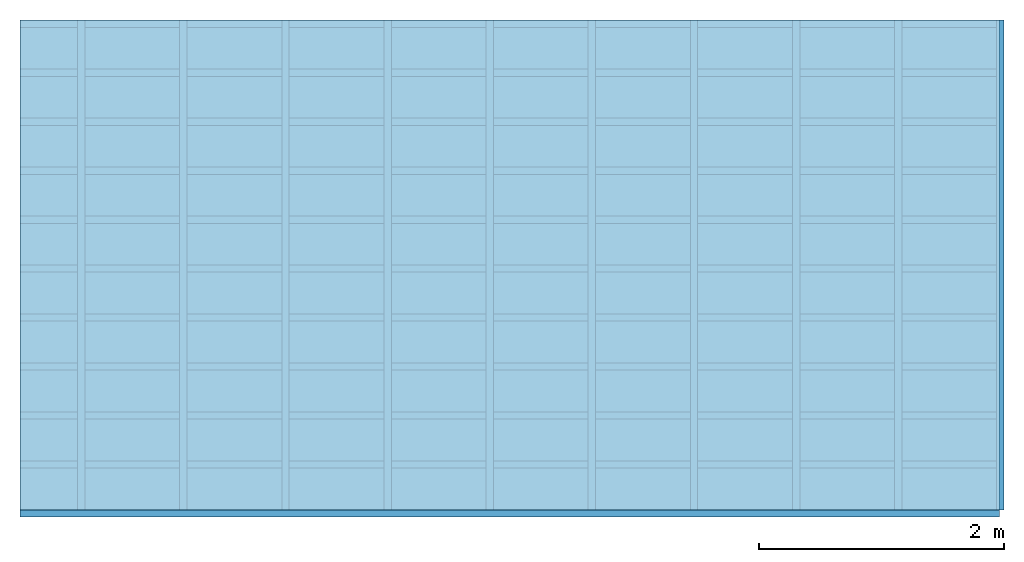
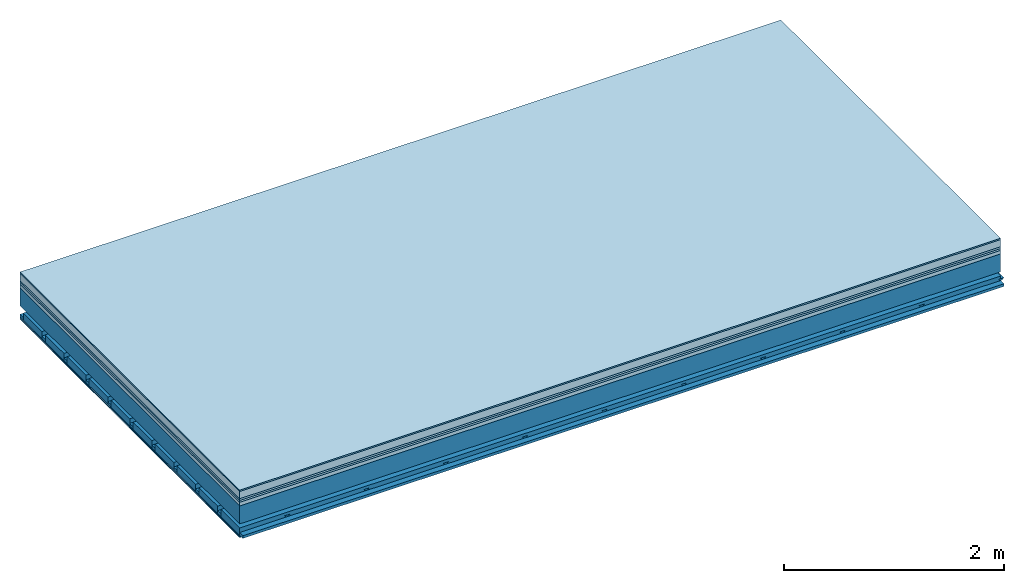
# One storey: 8 plates, 4 members, 1 element without a shape of its own.
"""IFC4 building model written with IfcOpenShell, lengths in metres."""

from ifc_helpers import new_model, si_unit, derived_unit, direction, frame, frame_2d, origin, origin_with_axes, place, context, project, spatial, polyline, rectangle, outline, extrude, material, layer, layer_set, type_object, element, aggregate, save


model = new_model("IFC4")

# Units and contexts
plan_context = context("Plan", 3, precision=1e-05, world=origin(), true_north=direction((0.0, 1.0)))
model_context = context("Model", 3, precision=1e-05, world=origin(), true_north=direction((0.0, 1.0)))
ifc_project = project(units=[si_unit("LENGTHUNIT", "METRE"), derived_unit("SOUNDPRESSUREUNIT", [(si_unit("PRESSUREUNIT", "PASCAL", prefix="MICRO"), 0)]), si_unit("ENERGYUNIT", "JOULE", prefix="MEGA"), si_unit("MASSUNIT", "GRAM", prefix="KILO"), derived_unit("THERMALTRANSMITTANCEUNIT", [(si_unit("POWERUNIT", "WATT"), 1), (si_unit("AREAUNIT", "SQUARE_METRE"), -1), (si_unit("THERMODYNAMICTEMPERATUREUNIT", "KELVIN"), -1)]), derived_unit("AREADENSITYUNIT", [(si_unit("MASSUNIT", "GRAM", prefix="KILO"), 1), (si_unit("AREAUNIT", "SQUARE_METRE"), -1)]), derived_unit("USERDEFINED", [(si_unit("ENERGYUNIT", "JOULE", prefix="MEGA"), 1), (si_unit("AREAUNIT", "SQUARE_METRE"), -1)])], contexts=[plan_context, model_context])

# Site, building, storey
site = spatial("IfcSite", under=ifc_project)
building_placement = place(None, origin())
building = spatial("IfcBuilding", under=site, at=building_placement)
storey_placement = place(building_placement, origin())
storey = spatial("IfcBuildingStorey", under=building, at=storey_placement)

# Slab, members, plates
ifc_material_1 = material(Category="11.013")
ifc_layer_1 = layer(ifc_material_1, 0.015, Name="Flooring")
ifc_material_2 = material(Name="Cement screed", Category="04.006")
ifc_layer_2 = layer(ifc_material_2, 0.08, Name="On-material")
ifc_material_3 = material(Name="Wood fiber generic product", Category="10.009")
ifc_layer_3 = layer(ifc_material_3, 0.02, Name="Impact sound insulation")
ifc_material_4 = material(Category="10.004")
ifc_layer_4 = layer(ifc_material_4, 0.02, Name="Additional insulation")
ifc_material_5 = material(Name="Garden plates", Category="02.007")
ifc_layer_5 = layer(ifc_material_5, 0.04, Name="on Supporting structure")
ifc_material_6 = material(Name="no composite action")
ifc_layer_6 = layer(ifc_material_6, 0.0, Name="Bond")
ifc_layer_7 = layer(None, 0.2, Name="Supporting structure")
ifc_layer_8 = layer(ifc_material_6, 0.0, Name="Bond")
ifc_layer_9 = layer(None, 0.095, Name="Coupling")
ifc_layer_10 = layer(None, 0.03, Name="Battens / profiles")
ifc_material_7 = material(Name="Plasterboard type A", Category="03.008")
ifc_layer_11 = layer(ifc_material_7, 0.0125, Name="Ceiling covering 1st layer")
ifc_layer_12 = layer(ifc_material_7, 0.0125, Name="Ceiling covering layer 2")
ifc_material_8 = material(Category="04.001")
ifc_layer_13 = layer(ifc_material_8, 0.003, Name="Surface / treatment")
ifc_layer_set = layer_set([ifc_layer_1, ifc_layer_2, ifc_layer_3, ifc_layer_4, ifc_layer_5, ifc_layer_6, ifc_layer_7, ifc_layer_8, ifc_layer_9, ifc_layer_10, ifc_layer_11, ifc_layer_12, ifc_layer_13])
slab_type = type_object("IfcSlabType", Name="A2172", PredefinedType="NOTDEFINED", material=ifc_layer_set)
slab_placement = place(None, frame((0.0, 0.0, 0.0), z_axis=(0.0, 0.0, -1.0), x_axis=(1.0, 0.0, 0.0)))
slab = element("IfcSlab", 1, at=slab_placement, inside=storey, type_object=slab_type, material=ifc_layer_set, Name="Slab #1")
ifc_material_9 = material(Name="Solid timber panel")
member_1_placement = place(slab_placement, origin())
member_1 = element("IfcMember", 2, at=member_1_placement, material=ifc_material_9, Name="Supporting structure", context=plan_context, shape_type="SweptSolid", body=[
    extrude(rectangle(XDim=1.0, YDim=0.2, at=frame_2d((0.5, 0.1), x_axis=(1.0, 0.0))), frame((0.0, 4.0, 0.175), z_axis=(0.0, -1.0, 0.0), x_axis=(1.0, 0.0, 0.0)), (0.0, 0.0, 1.0), 4.0),
    extrude(rectangle(XDim=1.0, YDim=0.2, at=frame_2d((0.5, 0.1), x_axis=(1.0, 0.0))), frame((1.0, 4.0, 0.175), z_axis=(0.0, -1.0, 0.0), x_axis=(1.0, 0.0, 0.0)), (0.0, 0.0, 1.0), 4.0),
    extrude(rectangle(XDim=1.0, YDim=0.2, at=frame_2d((0.5, 0.1), x_axis=(1.0, 0.0))), frame((2.0, 4.0, 0.175), z_axis=(0.0, -1.0, 0.0), x_axis=(1.0, 0.0, 0.0)), (0.0, 0.0, 1.0), 4.0),
    extrude(rectangle(XDim=1.0, YDim=0.2, at=frame_2d((0.5, 0.1), x_axis=(1.0, 0.0))), frame((3.0, 4.0, 0.175), z_axis=(0.0, -1.0, 0.0), x_axis=(1.0, 0.0, 0.0)), (0.0, 0.0, 1.0), 4.0),
    extrude(rectangle(XDim=1.0, YDim=0.2, at=frame_2d((0.5, 0.1), x_axis=(1.0, 0.0))), frame((4.0, 4.0, 0.175), z_axis=(0.0, -1.0, 0.0), x_axis=(1.0, 0.0, 0.0)), (0.0, 0.0, 1.0), 4.0),
    extrude(rectangle(XDim=1.0, YDim=0.2, at=frame_2d((0.5, 0.1), x_axis=(1.0, 0.0))), frame((5.0, 4.0, 0.175), z_axis=(0.0, -1.0, 0.0), x_axis=(1.0, 0.0, 0.0)), (0.0, 0.0, 1.0), 4.0),
    extrude(rectangle(XDim=1.0, YDim=0.2, at=frame_2d((0.5, 0.1), x_axis=(1.0, 0.0))), frame((6.0, 4.0, 0.175), z_axis=(0.0, -1.0, 0.0), x_axis=(1.0, 0.0, 0.0)), (0.0, 0.0, 1.0), 4.0),
    extrude(rectangle(XDim=1.0, YDim=0.2, at=frame_2d((0.5, 0.1), x_axis=(1.0, 0.0))), frame((7.0, 4.0, 0.175), z_axis=(0.0, -1.0, 0.0), x_axis=(1.0, 0.0, 0.0)), (0.0, 0.0, 1.0), 4.0),
])
ifc_material_10 = material()
member_2_placement = place(slab_placement, origin())
member_2 = element("IfcMember", 3, at=member_2_placement, material=ifc_material_10, Name="Coupling", context=plan_context, shape_type="SweptSolid", body=[
    extrude(outline(polyline([(0.0, 0.0), (0.06, 0.0), (0.04, 0.02), (0.02, 0.02), (0.0, 0.0)])), frame((0.47, 4.0, 0.45), z_axis=(0.0, -1.0, 0.0), x_axis=(1.0, 0.0, 0.0)), (0.0, 0.0, 1.0), 4.0),
    extrude(outline(polyline([(0.0, 0.0), (0.06, 0.0), (0.04, 0.02), (0.02, 0.02), (0.0, 0.0)])), frame((1.304, 4.0, 0.45), z_axis=(0.0, -1.0, 0.0), x_axis=(1.0, 0.0, 0.0)), (0.0, 0.0, 1.0), 4.0),
    extrude(outline(polyline([(0.0, 0.0), (0.06, 0.0), (0.04, 0.02), (0.02, 0.02), (0.0, 0.0)])), frame((2.138, 4.0, 0.45), z_axis=(0.0, -1.0, 0.0), x_axis=(1.0, 0.0, 0.0)), (0.0, 0.0, 1.0), 4.0),
    extrude(outline(polyline([(0.0, 0.0), (0.06, 0.0), (0.04, 0.02), (0.02, 0.02), (0.0, 0.0)])), frame((2.972, 4.0, 0.45), z_axis=(0.0, -1.0, 0.0), x_axis=(1.0, 0.0, 0.0)), (0.0, 0.0, 1.0), 4.0),
    extrude(outline(polyline([(0.0, 0.0), (0.06, 0.0), (0.04, 0.02), (0.02, 0.02), (0.0, 0.0)])), frame((3.806, 4.0, 0.45), z_axis=(0.0, -1.0, 0.0), x_axis=(1.0, 0.0, 0.0)), (0.0, 0.0, 1.0), 4.0),
    extrude(outline(polyline([(0.0, 0.0), (0.06, 0.0), (0.04, 0.02), (0.02, 0.02), (0.0, 0.0)])), frame((4.64, 4.0, 0.45), z_axis=(0.0, -1.0, 0.0), x_axis=(1.0, 0.0, 0.0)), (0.0, 0.0, 1.0), 4.0),
    extrude(outline(polyline([(0.0, 0.0), (0.06, 0.0), (0.04, 0.02), (0.02, 0.02), (0.0, 0.0)])), frame((5.474, 4.0, 0.45), z_axis=(0.0, -1.0, 0.0), x_axis=(1.0, 0.0, 0.0)), (0.0, 0.0, 1.0), 4.0),
    extrude(outline(polyline([(0.0, 0.0), (0.06, 0.0), (0.04, 0.02), (0.02, 0.02), (0.0, 0.0)])), frame((6.308, 4.0, 0.45), z_axis=(0.0, -1.0, 0.0), x_axis=(1.0, 0.0, 0.0)), (0.0, 0.0, 1.0), 4.0),
    extrude(outline(polyline([(0.0, 0.0), (0.06, 0.0), (0.04, 0.02), (0.02, 0.02), (0.0, 0.0)])), frame((7.142, 4.0, 0.45), z_axis=(0.0, -1.0, 0.0), x_axis=(1.0, 0.0, 0.0)), (0.0, 0.0, 1.0), 4.0),
    extrude(outline(polyline([(0.0, 0.0), (0.06, 0.0), (0.04, 0.02), (0.02, 0.02), (0.0, 0.0)])), frame((7.976, 4.0, 0.45), z_axis=(0.0, -1.0, 0.0), x_axis=(1.0, 0.0, 0.0)), (0.0, 0.0, 1.0), 4.0),
])
member_3_placement = place(slab_placement, origin())
member_3 = element("IfcMember", 4, at=member_3_placement, material=ifc_material_10, Name="Battens / profiles", context=plan_context, shape_type="SweptSolid", body=[
    extrude(rectangle(XDim=0.06, YDim=0.03, at=frame_2d((0.03, 0.015), x_axis=(1.0, 0.0))), frame((0.0, 0.0, 0.47), z_axis=(1.0, 0.0, 0.0), x_axis=(0.0, 1.0, 0.0)), (0.0, 0.0, 1.0), 8.0),
    extrude(rectangle(XDim=0.06, YDim=0.03, at=frame_2d((0.03, 0.015), x_axis=(1.0, 0.0))), frame((0.0, 0.4, 0.47), z_axis=(1.0, 0.0, 0.0), x_axis=(0.0, 1.0, 0.0)), (0.0, 0.0, 1.0), 8.0),
    extrude(rectangle(XDim=0.06, YDim=0.03, at=frame_2d((0.03, 0.015), x_axis=(1.0, 0.0))), frame((0.0, 0.8, 0.47), z_axis=(1.0, 0.0, 0.0), x_axis=(0.0, 1.0, 0.0)), (0.0, 0.0, 1.0), 8.0),
    extrude(rectangle(XDim=0.06, YDim=0.03, at=frame_2d((0.03, 0.015), x_axis=(1.0, 0.0))), frame((0.0, 1.2, 0.47), z_axis=(1.0, 0.0, 0.0), x_axis=(0.0, 1.0, 0.0)), (0.0, 0.0, 1.0), 8.0),
    extrude(rectangle(XDim=0.06, YDim=0.03, at=frame_2d((0.03, 0.015), x_axis=(1.0, 0.0))), frame((0.0, 1.6, 0.47), z_axis=(1.0, 0.0, 0.0), x_axis=(0.0, 1.0, 0.0)), (0.0, 0.0, 1.0), 8.0),
    extrude(rectangle(XDim=0.06, YDim=0.03, at=frame_2d((0.03, 0.015), x_axis=(1.0, 0.0))), frame((0.0, 2.0, 0.47), z_axis=(1.0, 0.0, 0.0), x_axis=(0.0, 1.0, 0.0)), (0.0, 0.0, 1.0), 8.0),
    extrude(rectangle(XDim=0.06, YDim=0.03, at=frame_2d((0.03, 0.015), x_axis=(1.0, 0.0))), frame((0.0, 2.4, 0.47), z_axis=(1.0, 0.0, 0.0), x_axis=(0.0, 1.0, 0.0)), (0.0, 0.0, 1.0), 8.0),
    extrude(rectangle(XDim=0.06, YDim=0.03, at=frame_2d((0.03, 0.015), x_axis=(1.0, 0.0))), frame((0.0, 2.8, 0.47), z_axis=(1.0, 0.0, 0.0), x_axis=(0.0, 1.0, 0.0)), (0.0, 0.0, 1.0), 8.0),
    extrude(rectangle(XDim=0.06, YDim=0.03, at=frame_2d((0.03, 0.015), x_axis=(1.0, 0.0))), frame((0.0, 3.2, 0.47), z_axis=(1.0, 0.0, 0.0), x_axis=(0.0, 1.0, 0.0)), (0.0, 0.0, 1.0), 8.0),
    extrude(rectangle(XDim=0.06, YDim=0.03, at=frame_2d((0.03, 0.015), x_axis=(1.0, 0.0))), frame((0.0, 3.6, 0.47), z_axis=(1.0, 0.0, 0.0), x_axis=(0.0, 1.0, 0.0)), (0.0, 0.0, 1.0), 8.0),
    extrude(rectangle(XDim=0.06, YDim=0.03, at=frame_2d((0.03, 0.015), x_axis=(1.0, 0.0))), frame((0.0, 4.0, 0.47), z_axis=(1.0, 0.0, 0.0), x_axis=(0.0, 1.0, 0.0)), (0.0, 0.0, 1.0), 8.0),
])
ifc_material_11 = material()
member_4_placement = place(slab_placement, origin())
member_4 = element("IfcMember", 5, at=member_4_placement, material=ifc_material_11, Name="Cavity", context=plan_context, shape_type="SweptSolid", body=[
    extrude(rectangle(XDim=0.34, YDim=0.08, at=frame_2d((0.17, 0.04), x_axis=(1.0, 0.0))), frame((0.0, 0.06, 0.42), z_axis=(1.0, 0.0, 0.0), x_axis=(0.0, 1.0, 0.0)), (0.0, 0.0, 1.0), 8.0),
    extrude(rectangle(XDim=0.34, YDim=0.08, at=frame_2d((0.17, 0.04), x_axis=(1.0, 0.0))), frame((0.0, 0.46, 0.42), z_axis=(1.0, 0.0, 0.0), x_axis=(0.0, 1.0, 0.0)), (0.0, 0.0, 1.0), 8.0),
    extrude(rectangle(XDim=0.34, YDim=0.08, at=frame_2d((0.17, 0.04), x_axis=(1.0, 0.0))), frame((0.0, 0.86, 0.42), z_axis=(1.0, 0.0, 0.0), x_axis=(0.0, 1.0, 0.0)), (0.0, 0.0, 1.0), 8.0),
    extrude(rectangle(XDim=0.34, YDim=0.08, at=frame_2d((0.17, 0.04), x_axis=(1.0, 0.0))), frame((0.0, 1.26, 0.42), z_axis=(1.0, 0.0, 0.0), x_axis=(0.0, 1.0, 0.0)), (0.0, 0.0, 1.0), 8.0),
    extrude(rectangle(XDim=0.34, YDim=0.08, at=frame_2d((0.17, 0.04), x_axis=(1.0, 0.0))), frame((0.0, 1.66, 0.42), z_axis=(1.0, 0.0, 0.0), x_axis=(0.0, 1.0, 0.0)), (0.0, 0.0, 1.0), 8.0),
    extrude(rectangle(XDim=0.34, YDim=0.08, at=frame_2d((0.17, 0.04), x_axis=(1.0, 0.0))), frame((0.0, 2.06, 0.42), z_axis=(1.0, 0.0, 0.0), x_axis=(0.0, 1.0, 0.0)), (0.0, 0.0, 1.0), 8.0),
    extrude(rectangle(XDim=0.34, YDim=0.08, at=frame_2d((0.17, 0.04), x_axis=(1.0, 0.0))), frame((0.0, 2.46, 0.42), z_axis=(1.0, 0.0, 0.0), x_axis=(0.0, 1.0, 0.0)), (0.0, 0.0, 1.0), 8.0),
    extrude(rectangle(XDim=0.34, YDim=0.08, at=frame_2d((0.17, 0.04), x_axis=(1.0, 0.0))), frame((0.0, 2.86, 0.42), z_axis=(1.0, 0.0, 0.0), x_axis=(0.0, 1.0, 0.0)), (0.0, 0.0, 1.0), 8.0),
    extrude(rectangle(XDim=0.34, YDim=0.08, at=frame_2d((0.17, 0.04), x_axis=(1.0, 0.0))), frame((0.0, 3.26, 0.42), z_axis=(1.0, 0.0, 0.0), x_axis=(0.0, 1.0, 0.0)), (0.0, 0.0, 1.0), 8.0),
    extrude(rectangle(XDim=0.34, YDim=0.08, at=frame_2d((0.17, 0.04), x_axis=(1.0, 0.0))), frame((0.0, 3.66, 0.42), z_axis=(1.0, 0.0, 0.0), x_axis=(0.0, 1.0, 0.0)), (0.0, 0.0, 1.0), 8.0),
])
plate_1_placement = place(slab_placement, origin())
plate_1 = element("IfcPlate", 6, at=plate_1_placement, material=ifc_material_1, Name="Flooring", context=plan_context, shape_type="SweptSolid", body=[
    extrude(rectangle(XDim=8.0, YDim=4.0, at=frame_2d((4.0, 2.0), x_axis=(1.0, 0.0))), origin_with_axes(), (0.0, 0.0, 1.0), 0.015),
])
plate_2_placement = place(slab_placement, origin())
plate_2 = element("IfcPlate", 7, at=plate_2_placement, material=ifc_material_2, Name="On-material", context=plan_context, shape_type="SweptSolid", body=[
    extrude(rectangle(XDim=8.0, YDim=4.0, at=frame_2d((4.0, 2.0), x_axis=(1.0, 0.0))), frame((0.0, 0.0, 0.015), z_axis=(0.0, 0.0, 1.0), x_axis=(1.0, 0.0, 0.0)), (0.0, 0.0, 1.0), 0.08),
])
plate_3_placement = place(slab_placement, origin())
plate_3 = element("IfcPlate", 8, at=plate_3_placement, material=ifc_material_3, Name="Impact sound insulation", context=plan_context, shape_type="SweptSolid", body=[
    extrude(rectangle(XDim=8.0, YDim=4.0, at=frame_2d((4.0, 2.0), x_axis=(1.0, 0.0))), frame((0.0, 0.0, 0.095), z_axis=(0.0, 0.0, 1.0), x_axis=(1.0, 0.0, 0.0)), (0.0, 0.0, 1.0), 0.02),
])
plate_4_placement = place(slab_placement, origin())
plate_4 = element("IfcPlate", 9, at=plate_4_placement, material=ifc_material_4, Name="Additional insulation", context=plan_context, shape_type="SweptSolid", body=[
    extrude(rectangle(XDim=8.0, YDim=4.0, at=frame_2d((4.0, 2.0), x_axis=(1.0, 0.0))), frame((0.0, 0.0, 0.115), z_axis=(0.0, 0.0, 1.0), x_axis=(1.0, 0.0, 0.0)), (0.0, 0.0, 1.0), 0.02),
])
plate_5_placement = place(slab_placement, origin())
plate_5 = element("IfcPlate", 10, at=plate_5_placement, material=ifc_material_5, Name="on Supporting structure", context=plan_context, shape_type="SweptSolid", body=[
    extrude(rectangle(XDim=8.0, YDim=4.0, at=frame_2d((4.0, 2.0), x_axis=(1.0, 0.0))), frame((0.0, 0.0, 0.135), z_axis=(0.0, 0.0, 1.0), x_axis=(1.0, 0.0, 0.0)), (0.0, 0.0, 1.0), 0.04),
])
plate_6_placement = place(slab_placement, origin())
plate_6 = element("IfcPlate", 11, at=plate_6_placement, material=ifc_material_7, Name="Ceiling covering 1st layer", context=plan_context, shape_type="SweptSolid", body=[
    extrude(rectangle(XDim=8.0, YDim=4.0, at=frame_2d((4.0, 2.0), x_axis=(1.0, 0.0))), frame((0.0, 0.0, 0.5), z_axis=(0.0, 0.0, 1.0), x_axis=(1.0, 0.0, 0.0)), (0.0, 0.0, 1.0), 0.0125),
])
plate_7_placement = place(slab_placement, origin())
plate_7 = element("IfcPlate", 12, at=plate_7_placement, material=ifc_material_7, Name="Ceiling covering layer 2", context=plan_context, shape_type="SweptSolid", body=[
    extrude(rectangle(XDim=8.0, YDim=4.0, at=frame_2d((4.0, 2.0), x_axis=(1.0, 0.0))), frame((0.0, 0.0, 0.5125), z_axis=(0.0, 0.0, 1.0), x_axis=(1.0, 0.0, 0.0)), (0.0, 0.0, 1.0), 0.0125),
])
plate_8_placement = place(slab_placement, origin())
plate_8 = element("IfcPlate", 13, at=plate_8_placement, material=ifc_material_8, Name="Surface / treatment", context=plan_context, shape_type="SweptSolid", body=[
    extrude(rectangle(XDim=8.0, YDim=4.0, at=frame_2d((4.0, 2.0), x_axis=(1.0, 0.0))), frame((0.0, 0.0, 0.525), z_axis=(0.0, 0.0, 1.0), x_axis=(1.0, 0.0, 0.0)), (0.0, 0.0, 1.0), 0.003),
])
aggregate(slab, [plate_1, plate_2, plate_3, plate_4, plate_5, member_1, member_2, member_3, member_4, plate_6, plate_7, plate_8])

save(model, "model.ifc")
